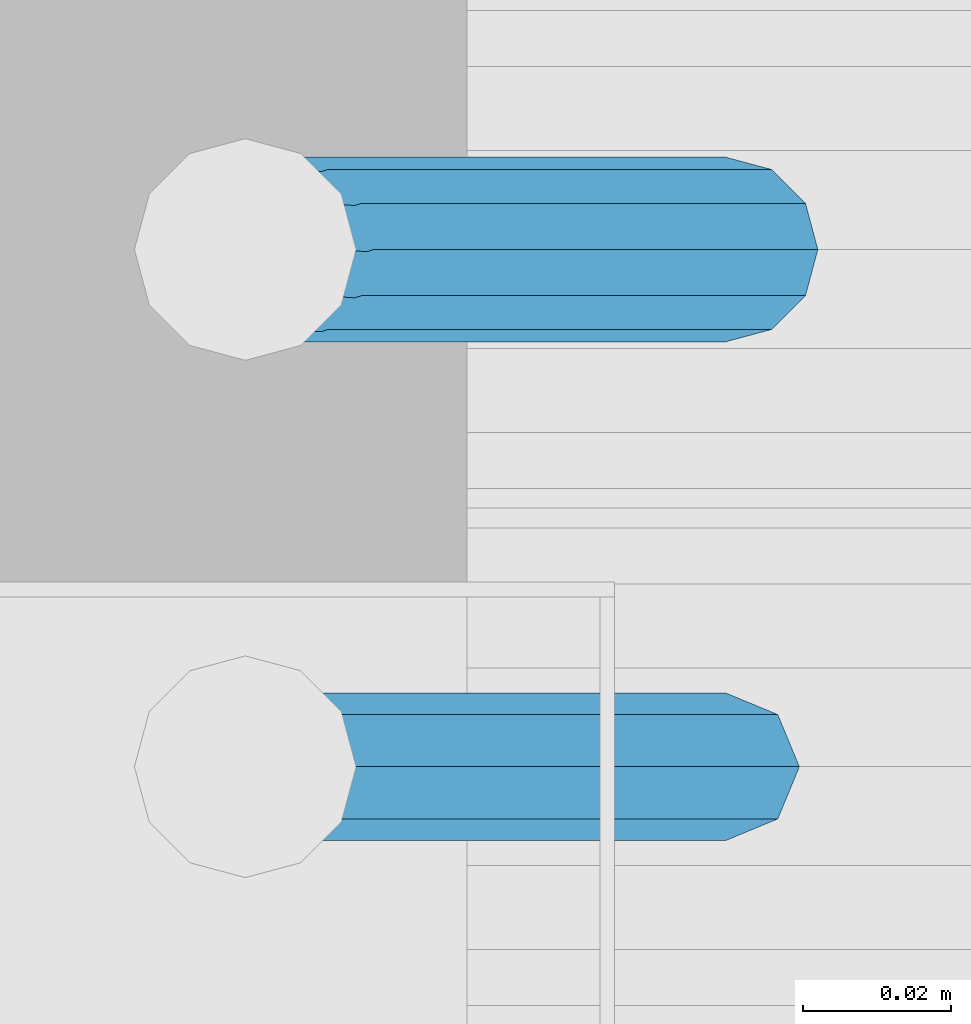
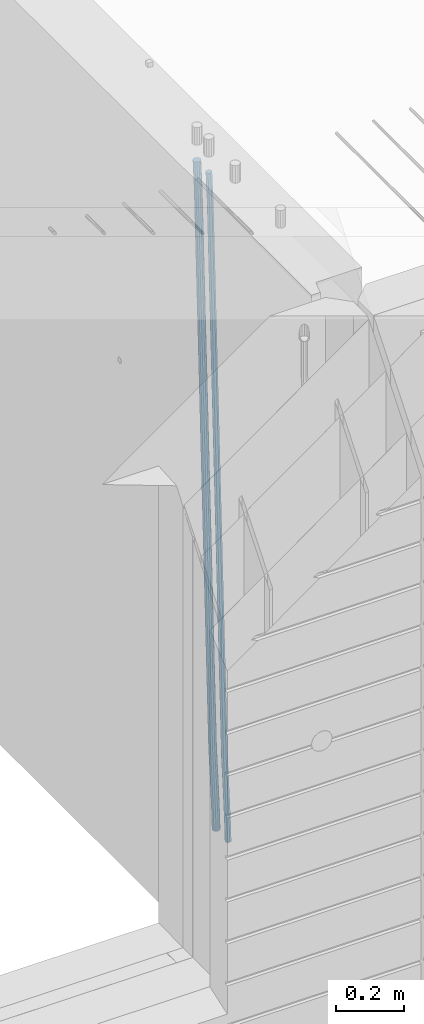
# One storey, part 102 of 350: 2 beams, 1 element without a shape of its own.
"""IFC2X3 building model written with IfcOpenShell, lengths in millimetres."""

from ifc_helpers import new_model, si_unit, frame, origin_with_axes, place, context, subcontext, project, spatial, faceted_brep, material, type_object, element, aggregate, save


model = new_model("IFC2X3")

# Units and contexts
model_context = context("Model", 3, precision=1e-05, world=origin_with_axes())
body_context = subcontext(model_context, "Body", "Model", "MODEL_VIEW")
ifc_project = project(units=[si_unit("LENGTHUNIT", "METRE", prefix="MILLI"), si_unit("AREAUNIT", "SQUARE_METRE"), si_unit("VOLUMEUNIT", "CUBIC_METRE"), si_unit("MASSUNIT", "GRAM", prefix="KILO"), si_unit("TIMEUNIT", "SECOND"), si_unit("PLANEANGLEUNIT", "RADIAN"), si_unit("SOLIDANGLEUNIT", "STERADIAN"), si_unit("THERMODYNAMICTEMPERATUREUNIT", "DEGREE_CELSIUS"), si_unit("LUMINOUSINTENSITYUNIT", "LUMEN")], contexts=[model_context])

# Site, building, storey
site_placement = place(None, origin_with_axes())
site = spatial("IfcSite", under=ifc_project, at=site_placement, CompositionType="ELEMENT")
building_placement = place(site_placement, origin_with_axes())
building = spatial("IfcBuilding", under=site, at=building_placement, CompositionType="ELEMENT")
storey_placement = place(building_placement, origin_with_axes())
storey = spatial("IfcBuildingStorey", under=building, at=storey_placement, Name="2", CompositionType="ELEMENT", Elevation=0.0)

# Assembly, beams
assembly_placement = place(storey_placement, origin_with_axes())
assembly = element("IfcElementAssembly", 1, at=assembly_placement, inside=storey, AssemblyPlace="NOTDEFINED", PredefinedType="REINFORCEMENT_UNIT")
ifc_material = material()
beam_type_1 = type_object("IfcBeamType", Name="D20", PredefinedType="NOTDEFINED")
beam_1_placement = place(assembly_placement, frame((21875.0000022791, 8805.00000000393, 84990.0), z_axis=(-0.999642804636942, -0.000205726999925762, -0.0267249099902983), x_axis=(-0.0267249099948371, 4.30000201934385e-08, 0.999642825806181)))
beam_1 = element("IfcBeam", 2, at=beam_1_placement, type_object=beam_type_1, material=ifc_material, Name="JM20", ObjectType="D20", context=body_context, shape_type="Brep", body=[
    faceted_brep([(0.0, -10.0, 0.0), (-4.19531716033816e-08, -7.07106781186667, -7.07106781187031), (60.4266690400545, -7.0710677960451, -7.07106780570757), (60.4266690441291, -9.99999998418934, 6.15546014159918e-09), (0.0, 0.0, -10.0), (60.426669036824, 1.58106558956206e-08, -9.99999999384454), (4.196772351861e-08, 7.07106781186303, -7.07106781186667), (60.4266690363438, 7.07106782768096, -7.07106780570757), (0.0, 10.0, 0.0), (60.4266690388904, 10.0000000158179, 6.15182216279209e-09), (4.196772351861e-08, 7.07106781185939, 7.07106781185939), (60.4266690429649, 7.07106782768096, 7.07106781802577), (0.0, 0.0, 10.0), (60.4266690461809, 1.58179318532348e-08, 10.0000000061555), (-4.19531716033816e-08, -7.07106781187031, 7.07106781185939), (60.4266690466611, -7.07106779605238, 7.07106781802213), (61.0378400410118, -7.07106779588503, -7.07106780564936), (60.991799419251, -9.99999998403655, 6.21366780251265e-09), (61.0569027789461, 1.5985278878361e-08, -9.99999999378269), (61.0378209396877, 7.07106782784831, -7.07106780564936), (60.9917724058905, 10.0000000159635, 6.21366780251265e-09), (60.9457317841297, 7.07106782781193, 7.0710678180767), (60.9266690461809, 1.59488990902901e-08, 10.0000000062028), (60.9457508854539, -7.07106779591413, 7.0710678180767), (61.6489592143771, -7.07106614513759, -7.06310863441468), (61.5568818710308, -9.9999984576425, 0.00735959856683621), (61.6870830769039, 1.71821739058942e-06, -9.99179257185824), (61.6489210170112, 7.07106947854481, -7.06310888312146), (61.556827851804, 10.0000015422847, 0.00735924683976918), (61.4647505084577, 7.07106922979438, 7.07782747982128), (61.4266266459163, 1.36643211590126e-06, 10.0065114172685), (61.464788705809, -7.07106639389531, 7.07782772852806), (176.543135720174, -7.07075579406956, -5.56673531796696), (176.451058376813, -9.99968810657447, 1.50373291501455), (176.581259582701, 0.000312069292704109, -8.49541925541052), (176.543097522794, 7.07137982961285, -5.56673556667374), (176.451004357587, 10.00031189336, 1.50373256329476), (176.35892701424, 7.07137958085514, 8.57420079627263), (176.320803151699, 0.000311717507429421, 11.5028847337162), (176.358965211621, -7.07075604281999, 8.57420104497578), (177.098753836006, -7.07075429323595, -5.55949898843028), (176.98362511232, -9.99968666800123, 1.510669025065), (177.146421932586, 0.000313595905026887, -8.48805862247536), (177.098706077581, 7.07138133041735, -5.55949936166144), (176.983557571715, 10.0003133318824, 1.51066849724157), (176.868428848029, 7.07138095712435, 8.58083651073321), (176.820760751449, 0.000313067976094317, 11.5093961447819), (176.868476606425, -7.07075466652896, 8.58083688396073), (177.654312950661, -7.07075204110879, -5.54863964998367), (177.516135294456, -9.99968450931192, 1.52107783331303), (177.711524267797, 0.000315886711177882, -8.47701274570863), (177.654255632195, 7.07138358250813, -5.54864021007961), (177.516054233929, 10.0003154905207, 1.5210770412159), (177.377876577739, 7.0713830223176, 8.59079452451624), (177.320665260588, 0.000315094497636892, 11.5191676202448), (177.377933896176, -7.07075260129932, 8.59079508461218), (299.499456785634, -7.07025810522464, -3.16697112782276), (299.361279129444, -9.99919057342777, 3.90274635547394), (299.556668102785, 0.000809822595329024, -6.09534422354773), (299.499399467197, 7.07187751838501, -3.1669716879187), (299.361198068917, 10.0008094264049, 3.90274556338045), (299.223020412712, 7.07187695819448, 10.9724630466735), (299.165809095575, 0.000809030381788034, 13.9008361423985), (299.223077731163, -7.07025866542244, 10.9724636067695), (300.03174732349, -7.07025594743027, -3.15656661289177), (299.971788958996, -9.99918809853989, 3.91467979818117), (300.056572611924, 0.000811849109595641, -6.08557274808481), (300.031722507032, 7.07187967631762, -3.15656653768019), (299.971753863239, 10.0008119014747, 3.91467990454839), (299.91179549876, 7.07187975035777, 10.9859263156177), (299.886970210311, 0.000811953817901667, 13.9149324508144), (299.911820315203, -7.0702558733974, 10.9859262404061), (300.564137759997, -7.07025623699155, -3.15794273276697), (300.582413367199, -9.99918843065097, 3.91310145956595), (300.556570941641, 0.000811577163403854, -6.0868651410201), (300.564145451674, 7.07187938674906, -3.15794274158179), (300.582424244858, 10.0008115693345, 3.91310144710224), (300.600699852032, 7.07187937566778, 10.9841456394352), (300.608266670402, 0.000811561512819026, 13.9130680476919), (300.600692160384, -7.07025624805829, 10.98414564825), (2294.16589219622, -7.0713405251372, -8.31099358700158), (2294.1841678034, -10.0002727187966, -1.23994939466866), (2294.15832537785, -0.000272710982244462, -11.2399159952547), (2294.16589988787, 7.07079509858886, -8.31099359582004), (2294.18417868105, 9.99972728118883, -1.23994940713601), (2294.20245428824, 7.07079508752213, 5.83109478519327), (2294.2100211066, -0.00027272663282929, 8.76001719345368), (2294.20244659658, -7.07134053620393, 5.83109479401173), (2294.7782683276, -7.07134085819416, -8.31257645345977), (2294.72126025338, -10.000273010919, -1.24133766827799), (2294.84007459224, -0.000273081772320438, -11.2416781768807), (2294.87047377572, 7.07079471537872, -8.31281477453012), (2294.85165844864, 9.9997269181622, -1.24167470516841), (2294.7946503744, 7.07079476544459, 5.82956408001337), (2294.73284410976, -0.000273010977252852, 8.75866580342336), (2294.7024449263, -7.07134080815013, 5.82980240107645), (2295.39054023061, -7.0793250091956, -8.30442771922026), (2295.25826128852, -10.0072756143927, -1.23419071494573), (2295.52170777075, -0.00916171800054144, -11.2326063125765), (2295.57492774284, 7.06160849139269, -8.30343918807193), (2295.51902460904, 9.99102432676591, -1.23279272078435), (2295.38674566693, 7.06307372157607, 5.83744428349019), (2295.25557812679, -0.0070895696117077, 8.76562287684646), (2295.20235815471, -7.07785977901949, 5.83645575234186), (2317.1947101649, -7.36365585014573, -8.01423575520312), (2317.06243122277, -10.2916064553428, -0.94399875092131), (2317.32587770502, -0.293492558957951, -10.9424143485521), (2317.37909767711, 6.77727765044983, -8.01324722405116), (2317.32319454331, 9.70669348581578, -0.942600756767206), (2317.1909156012, 6.77874288063322, 6.12763624751096), (2317.05974806109, -0.291420410569117, 9.0558148408636), (2317.00652808898, -7.36219061996962, 6.12664771636264), (2317.83015404257, -7.37194216843636, -8.00577862486898), (2317.72252095213, -10.300214160583, -0.935213608652703), (2317.90419832576, -0.301033978277701, -10.9347174723516), (2317.90127966482, 6.77046829039318, -8.00629749759901), (2317.82310777172, 9.70017451494641, -0.935947405505431), (2317.71547468127, 6.77190252279979, 6.13461761071085), (2317.64143039809, -0.29900566735887, 9.06355645819713), (2317.64434905903, -7.37050793602975, 6.13513648344451), (2318.46565174212, -7.3700661537805, -7.99751648408346), (2318.38266643914, -10.2982456018653, -0.926623872735945), (2318.48256818345, -0.299336209594912, -10.9272153854981), (2318.42350634121, 6.77200652527245, -7.99954269419686), (2318.32306384158, 9.70166538090416, -0.929489366557391), (2318.2400785386, 6.77348593281204, 6.14140324480104), (2318.22316209726, -0.297244011366274, 9.07110214621207), (2318.2822239395, -7.36858674623363, 6.1434294549108), (2418.48643733139, -7.07180401323421, -6.70013846199799), (2418.4034520284, -9.99998346132634, 0.370754149349523), (2418.5033537727, -0.00107406904135132, -9.62983736341266), (2418.44429193046, 7.07026866581873, -6.70216467211139), (2418.34384943081, 9.99992752145772, 0.367888655531715), (2418.26086412782, 7.0717480733656, 7.43878126688651), (2418.24394768651, 0.00101812917273492, 10.3684801682975), (2418.30300952874, -7.07032460568735, 7.44080747699627)], [[[0, 1, 2, 3]], [[1, 4, 5, 2]], [[4, 6, 7, 5]], [[6, 8, 9, 7]], [[8, 10, 11, 9]], [[10, 12, 13, 11]], [[12, 14, 15, 13]], [[14, 0, 3, 15]], [[14, 12, 10, 8, 6, 4, 1, 0]], [[3, 2, 16, 17]], [[2, 5, 18, 16]], [[5, 7, 19, 18]], [[7, 9, 20, 19]], [[9, 11, 21, 20]], [[11, 13, 22, 21]], [[13, 15, 23, 22]], [[15, 3, 17, 23]], [[17, 16, 24, 25]], [[16, 18, 26, 24]], [[18, 19, 27, 26]], [[19, 20, 28, 27]], [[20, 21, 29, 28]], [[21, 22, 30, 29]], [[22, 23, 31, 30]], [[23, 17, 25, 31]], [[25, 24, 32, 33]], [[24, 26, 34, 32]], [[26, 27, 35, 34]], [[27, 28, 36, 35]], [[28, 29, 37, 36]], [[29, 30, 38, 37]], [[30, 31, 39, 38]], [[31, 25, 33, 39]], [[33, 32, 40, 41]], [[32, 34, 42, 40]], [[34, 35, 43, 42]], [[35, 36, 44, 43]], [[36, 37, 45, 44]], [[37, 38, 46, 45]], [[38, 39, 47, 46]], [[39, 33, 41, 47]], [[41, 40, 48, 49]], [[40, 42, 50, 48]], [[42, 43, 51, 50]], [[43, 44, 52, 51]], [[44, 45, 53, 52]], [[45, 46, 54, 53]], [[46, 47, 55, 54]], [[47, 41, 49, 55]], [[49, 48, 56, 57]], [[48, 50, 58, 56]], [[50, 51, 59, 58]], [[51, 52, 60, 59]], [[52, 53, 61, 60]], [[53, 54, 62, 61]], [[54, 55, 63, 62]], [[55, 49, 57, 63]], [[57, 56, 64, 65]], [[56, 58, 66, 64]], [[58, 59, 67, 66]], [[59, 60, 68, 67]], [[60, 61, 69, 68]], [[61, 62, 70, 69]], [[62, 63, 71, 70]], [[63, 57, 65, 71]], [[65, 64, 72, 73]], [[64, 66, 74, 72]], [[66, 67, 75, 74]], [[67, 68, 76, 75]], [[68, 69, 77, 76]], [[69, 70, 78, 77]], [[70, 71, 79, 78]], [[71, 65, 73, 79]], [[73, 72, 80, 81]], [[72, 74, 82, 80]], [[74, 75, 83, 82]], [[75, 76, 84, 83]], [[76, 77, 85, 84]], [[77, 78, 86, 85]], [[78, 79, 87, 86]], [[79, 73, 81, 87]], [[81, 80, 88, 89]], [[80, 82, 90, 88]], [[82, 83, 91, 90]], [[83, 84, 92, 91]], [[84, 85, 93, 92]], [[85, 86, 94, 93]], [[86, 87, 95, 94]], [[87, 81, 89, 95]], [[89, 88, 96, 97]], [[88, 90, 98, 96]], [[90, 91, 99, 98]], [[91, 92, 100, 99]], [[92, 93, 101, 100]], [[93, 94, 102, 101]], [[94, 95, 103, 102]], [[95, 89, 97, 103]], [[97, 96, 104, 105]], [[96, 98, 106, 104]], [[98, 99, 107, 106]], [[99, 100, 108, 107]], [[100, 101, 109, 108]], [[101, 102, 110, 109]], [[102, 103, 111, 110]], [[103, 97, 105, 111]], [[105, 104, 112, 113]], [[104, 106, 114, 112]], [[106, 107, 115, 114]], [[107, 108, 116, 115]], [[108, 109, 117, 116]], [[109, 110, 118, 117]], [[110, 111, 119, 118]], [[111, 105, 113, 119]], [[113, 112, 120, 121]], [[112, 114, 122, 120]], [[114, 115, 123, 122]], [[115, 116, 124, 123]], [[116, 117, 125, 124]], [[117, 118, 126, 125]], [[118, 119, 127, 126]], [[119, 113, 121, 127]], [[121, 120, 128, 129]], [[120, 122, 130, 128]], [[122, 123, 131, 130]], [[123, 124, 132, 131]], [[124, 125, 133, 132]], [[125, 126, 134, 133]], [[126, 127, 135, 134]], [[127, 121, 129, 135]], [[130, 131, 132, 133, 134, 135, 129, 128]]]),
])
beam_type_2 = type_object("IfcBeamType", Name="D25", PredefinedType="NOTDEFINED")
beam_2_placement = place(assembly_placement, frame((21875.0000022791, 8875.00000000393, 84990.0), z_axis=(-0.999642804636942, -0.000205726999925762, -0.0267249099902983), x_axis=(-0.0267249099948371, 4.30000201934385e-08, 0.999642825806181)))
beam_2 = element("IfcBeam", 3, at=beam_2_placement, type_object=beam_type_2, material=ifc_material, Name="JM25", ObjectType="D25", context=body_context, shape_type="Brep", body=[
    faceted_brep([(-7.41420080885291e-08, -12.5, -3.63797880709171e-12), (-6.42030499875546e-08, -10.8253175473074, -6.25000000000364), (60.4103898235917, -10.8253175318459, -6.2499999938409), (60.4103898269532, -12.4999999845422, 6.16273609921336e-09), (-3.70782800018787e-08, -6.25000000000364, -10.8253175473074), (60.4103898202884, -6.24999998454587, -10.8253175411446), (-1.45519152283669e-11, -3.63797880709171e-12, -12.5), (60.4103898179019, 1.54577719513327e-08, -12.4999999938373), (3.70637280866504e-08, 6.25, -10.8253175473074), (60.410389817087, 6.25000001545777, -10.825317541141), (6.42030499875546e-08, 10.8253175473001, -6.25000000000364), (60.410389818062, 10.8253175627578, -6.24999999383726), (7.41420080885291e-08, 12.4999999999927, 0.0), (60.4103898205503, 12.5000000154541, 6.16273609921336e-09), (6.42176019027829e-08, 10.8253175473001, 6.24999999999636), (60.4103898238973, 10.8253175627651, 6.2500000061591), (3.70928319171071e-08, 6.24999999999636, 10.8253175473037), (60.4103898272151, 6.25000001546141, 10.8253175534664), (1.45519152283669e-11, -3.63797880709171e-12, 12.4999999999964), (60.4103898296162, 1.54541339725256e-08, 12.5000000061591), (-3.7049176171422e-08, -6.25000000000364, 10.8253175473001), (60.4103898304165, -6.24999998454587, 10.8253175534701), (-6.41884980723262e-08, -10.8253175473074, 6.25), (60.4103898294561, -10.8253175318459, 6.25000000616637), (61.0324985728803, -10.8253175316895, -6.24999999377542), (60.991802792938, -12.4999999843931, 6.22458173893392e-09), (61.0622854283865, -6.24999998437852, -10.8253175410755), (61.0731819955545, 1.5628756955266e-08, -12.4999999937718), (61.0622685480339, 6.25000001562512, -10.8253175410791), (61.032469335245, 10.8253175629216, -6.24999999377178), (60.9917690322181, 12.5000000156033, 6.22458173893392e-09), (60.9510732522613, 10.8253175629034, 6.25000000621731), (60.9212863967696, 6.25000001558874, 10.8253175535247), (60.9103898296162, 1.55814632307738e-08, 12.5000000062137), (60.9213032771368, -6.24999998441126, 10.8253175535174), (60.9511024898966, -10.8253175317113, 6.25000000621731), (61.6545545670233, -10.8253158516927, -6.24189838219536), (61.573166454793, -12.499998414296, 0.00757164385504439), (61.7141257553885, -6.24999822394238, -10.8168280205282), (61.7359179680789, 1.80548886419274e-06, -12.491368569139), (61.7140919992817, 6.25000177601396, -10.8168282403167), (61.6544960997562, 10.8253192428383, -6.2418987628771), (61.5730989426083, 12.5000015856094, 0.0075712042817031), (61.4917108303925, 10.8253190230062, 6.25704123032847), (61.4321396420273, 6.25000139525582, 10.8319708686649), (61.4103474293224, 1.36582457344048e-06, 12.5065114172721), (61.4321733981196, -6.24999860470052, 10.8319710884571), (61.4917692976451, -10.8253160715249, 6.25704161101385), (176.524302641745, -10.8250056210964, -4.74584321979273), (176.442914529529, -12.4996881836996, 1.50362680625403), (176.583873830095, -6.24968799334965, -9.3207728581292), (176.605666042786, 0.000312036081595579, -10.9953134067364), (176.583840074018, 6.25031200660669, -9.32077307791769), (176.524244174492, 10.8256294734347, -4.74584360047811), (176.44284701733, 12.5003118162058, 1.50362636668069), (176.361458905099, 10.8256292535989, 7.75309639272746), (176.301887716749, 6.25031162585219, 12.3280260310676), (176.280095504058, 0.000311596420942806, 14.0025665796711), (176.301921472827, -6.24968837410415, 12.3280262508561), (176.361517372367, -10.8250058409321, 7.75309677341284), (177.085397012124, -10.8250041057399, -4.73853556792164), (176.983633547483, -12.4996867233749, 1.51066909103247), (177.159881729676, -6.24968643771717, -9.31327097355097), (177.187129580227, 0.000313606451527448, -10.987740468332), (177.159839524218, 6.25031356221734, -9.31327130338468), (177.085323910098, 10.8256309887511, -4.73853613920801), (176.983549136537, 12.5003132764905, 1.51066843136869), (176.881785671867, 10.8256306588555, 7.7598730903228), (176.80730095433, 6.25031299082912, 12.3346084959521), (176.780053103794, 0.000312946667690994, 14.0090779907332), (176.807343159802, -6.2496870091054, 12.3346088257895), (176.881858773908, -10.8250044356355, 7.7598736616128), (177.646431799818, -10.8250018318176, -4.72756919822132), (177.524295146417, -12.4996845320202, 1.52123723245313), (177.735828462886, -6.24968410334986, -9.30201312475765), (177.768531371941, 0.00031596292683389, -10.9763759912421), (177.735777808921, 6.25031589654827, -9.30201361973741), (177.646344064575, 10.8256332626152, -4.72757005553649), (177.524193838486, 12.5003154677688, 1.52123624250817), (177.402057185071, 10.8256327675663, 7.77004267317898), (177.312660521988, 6.2503150390985, 12.3444865997226), (177.279957612933, 0.00031497282179771, 14.0188494661961), (177.312711175953, -6.24968496079964, 12.3444870946951), (177.402144920314, -10.8250023268702, 7.77004353049415), (299.455768830812, -10.8245081283076, -2.3466005802984), (299.333632177397, -12.4991908285119, 3.90220585037241), (299.545165493895, -6.24919039983797, -6.92104450684201), (299.577868402965, 0.000809666431450751, -8.59540737331918), (299.545114839959, 6.25080960005653, -6.92104500181449), (299.455681095627, 10.826126966127, -2.34660143761721), (299.333530869539, 12.5008091712825, 3.90220486042381), (299.211394216109, 10.8261264710764, 10.1510112911019), (299.12199755304, 6.25080874260857, 14.7254552176419), (299.089294643942, 0.000808676333690528, 16.399818084119), (299.122048206962, -6.24919125728957, 14.725455712618), (299.211481951279, -10.8245086233583, 10.1510121484171), (300.024791154356, -10.8245058220109, -2.33547808076037), (299.97179243555, -12.4991882411778, 3.91467976726199), (300.063582369272, -6.24918829865055, -6.91091117600809), (300.077772912133, 0.000811692589195445, -8.58563589785263), (300.063560438372, 6.250811701364, -6.91091110953494), (300.02475316888, 10.8261292726274, -2.33547796563289), (299.971750386685, 12.5008117588586, 3.91467993563856), (299.918751667865, 10.8261293380583, 10.1648377836791), (299.879960452934, 6.25081181469795, 14.7402708789268), (299.865769910102, 0.000811823456388083, 16.4149956007714), (299.879982383849, -6.2491881853166, 14.7402708124573), (299.918789653355, -10.8245057565764, 10.1648376685516), (300.593920270287, -10.8245061315029, -2.33694916256718), (300.610074274839, -12.4991885890868, 3.91302995994556), (300.582096539598, -6.24918858061756, -6.91225142858093), (300.577771241835, 0.000811420690297382, -8.58692829078791), (300.582103337059, 6.25081141938063, -6.91225143636984), (300.593932043848, 10.8261289631064, -2.33694917606044), (300.610087869776, 12.5008114109114, 3.9130299443641), (300.626241874328, 10.8261289533239, 10.1630090668841), (300.638065605017, 6.25081140244038, 14.7383113328942), (300.642390902765, 0.000811401132523315, 16.4129881951012), (300.638058807541, -6.24918859755599, 14.7383113406868), (300.626230100752, -10.8245061412817, 10.1630090803737), (2294.14353285028, -10.8255902228266, -7.48986524046995), (2294.15968685482, -12.5002726804123, -1.23988611794994), (2294.13170911958, -6.25027267194127, -12.0651675064764), (2294.12738382183, -0.000272670631602523, -13.7398443686834), (2294.13171591706, 6.24972732805691, -12.0651675142726), (2294.14354462385, 10.8250448717827, -7.48986525395958), (2294.15970044976, 12.4997273195859, -1.23988613352776), (2294.17585445431, 10.8250448620001, 5.01009298898498), (2294.187678185, 6.24972731111666, 9.58539525499873), (2294.19200348278, -0.000272690191195579, 11.2600721172021), (2294.18767138754, -6.2502726888797, 9.585395262784), (2294.17584268075, -10.8255902326073, 5.0100930024746), (2294.74938878331, -10.8255905522892, -7.49143125355113), (2294.70496048078, -12.5002729769312, -1.24129553822058), (2294.80375011452, -6.25027303739807, -12.0669045943469), (2294.85347839963, -0.00027306548145134, -13.7417211739557), (2294.88524898475, 6.24972691828589, -12.0671152424002), (2294.89054896731, 10.8250444655641, -7.49179610668216), (2294.86795822125, 12.4997269344367, -1.2417168343236), (2294.82352991869, 10.8250445097965, 5.00841888100695), (2294.76916858749, 6.24972699490354, 9.58389222179903), (2294.71944030239, -0.000272977013082709, 11.2587088014079), (2294.68766971726, -6.2502729607786, 9.58410286985236), (2294.68236973471, -10.825590508055, 5.0087837341307), (2295.35514159774, -10.8334896929118, -7.48336928222852), (2295.25014129943, -12.5073822463346, -1.23403972030064), (2295.47567672595, -6.25903509786804, -12.0579619151831), (2295.5794493938, -0.00973987576071522, -13.7320592174692), (2295.63865379873, 6.23990236538521, -12.0570881688836), (2295.63742616826, 10.8153050340698, -7.48185590923822), (2295.57609544498, 12.4904926801701, -1.23229222769442), (2295.47109514667, 10.8166001267491, 5.01703733422983), (2295.35056001844, 6.24214553170532, 9.59162996718442), (2295.24678735061, -0.00714969040200231, 11.2657272694705), (2295.18758294567, -6.2567919315461, 9.59075622088494), (2295.18881057615, -10.8321946002325, 5.01552396123952), (2317.11481405119, -11.1172402731609, -7.19376954593827), (2317.00981375287, -12.7911328265836, -0.944439984010387), (2317.23534917941, -6.54278567811707, -11.7683621788929), (2317.33912184725, -0.29349045600793, -13.4424594811753), (2317.39832625218, 5.95615178513435, -11.7674884325897), (2317.3970986217, 10.5315544538207, -7.19225617294796), (2317.33576789842, 12.2067420999228, -0.942692491407797), (2317.23076760011, 10.5328495465001, 5.30663707051644), (2317.1102324719, 5.95839495145628, 9.88122970347831), (2317.00645980405, -0.290900270651036, 11.5553270057644), (2316.94725539912, -6.54054251179696, 9.8803559571752), (2316.94848302958, -11.1159451804797, 5.30512369752978), (2317.8004851227, -11.126181564201, -7.18464394159309), (2317.70994759697, -12.80026271514, -0.935121894457552), (2317.8836082904, -6.55123910954353, -11.7597344907699), (2317.93704431444, -0.301287487300215, -13.4345017240375), (2317.94647505535, 5.94900381260777, -11.7601931137251), (2317.90937355367, 10.5248742839121, -7.18543829986083), (2317.83568112683, 12.2002231291572, -0.936039140375215), (2317.74514360113, 10.52614197822, 5.31348290676033), (2317.6620204334, 5.95119952355708, 9.88857345594079), (2317.60858440938, -0.298752098682598, 11.5633406892048), (2317.59915366847, -6.54904339859058, 9.88903207889598), (2317.63625517016, -11.124913869895, 5.31427726503171), (2318.48621414759, -11.1241535473946, -7.1757201348446), (2318.41014051515, -12.7981747344165, -0.926005966604862), (2318.53192237136, -6.54933498770879, -11.7513083179474), (2318.53501770479, -0.299537993947524, -13.426745357352), (2318.4946707558, 5.95060937655398, -11.7530992513966), (2318.42169245677, 10.5263851832951, -7.17882212257246), (2318.33563728402, 12.2017139941127, -0.929587833499681), (2318.25956365156, 10.5276928070889, 5.32012633473278), (2318.21385542781, 5.95287424740127, 9.89571451784286), (2318.21076009437, -0.296922746361815, 11.5711515572511), (2318.25110704337, -6.54707011686151, 9.89750545128845), (2318.32408534238, -11.1228459236008, 5.32322832246064), (2418.48697597762, -10.8259511810775, -5.87860183186422), (2418.41090234517, -12.4999723680994, 0.371112336375518), (2418.53268420139, -6.25113262138984, -10.454190014967), (2418.53577953482, -0.00133562762675865, -12.1296270543789), (2418.49543258583, 6.24881174287475, -10.4559809484163), (2418.4224542868, 10.8245875496141, -5.88170381958844), (2418.33639911404, 12.499916360428, 0.367530469480698), (2418.26032548158, 10.8258951734078, 6.61724463772043), (2418.21461725782, 6.25107661372022, 11.1928328208196), (2418.21152192439, 0.00127961995895021, 12.8682698602315), (2418.25186887338, -6.24886775054256, 11.1946237542688), (2418.32484717241, -10.8246435572837, 6.62034662544102)], [[[0, 1, 2, 3]], [[1, 4, 5, 2]], [[4, 6, 7, 5]], [[6, 8, 9, 7]], [[8, 10, 11, 9]], [[10, 12, 13, 11]], [[12, 14, 15, 13]], [[14, 16, 17, 15]], [[16, 18, 19, 17]], [[18, 20, 21, 19]], [[20, 22, 23, 21]], [[22, 0, 3, 23]], [[22, 20, 18, 16, 14, 12, 10, 8, 6, 4, 1, 0]], [[3, 2, 24, 25]], [[2, 5, 26, 24]], [[5, 7, 27, 26]], [[7, 9, 28, 27]], [[9, 11, 29, 28]], [[11, 13, 30, 29]], [[13, 15, 31, 30]], [[15, 17, 32, 31]], [[17, 19, 33, 32]], [[19, 21, 34, 33]], [[21, 23, 35, 34]], [[23, 3, 25, 35]], [[25, 24, 36, 37]], [[24, 26, 38, 36]], [[26, 27, 39, 38]], [[27, 28, 40, 39]], [[28, 29, 41, 40]], [[29, 30, 42, 41]], [[30, 31, 43, 42]], [[31, 32, 44, 43]], [[32, 33, 45, 44]], [[33, 34, 46, 45]], [[34, 35, 47, 46]], [[35, 25, 37, 47]], [[37, 36, 48, 49]], [[36, 38, 50, 48]], [[38, 39, 51, 50]], [[39, 40, 52, 51]], [[40, 41, 53, 52]], [[41, 42, 54, 53]], [[42, 43, 55, 54]], [[43, 44, 56, 55]], [[44, 45, 57, 56]], [[45, 46, 58, 57]], [[46, 47, 59, 58]], [[47, 37, 49, 59]], [[49, 48, 60, 61]], [[48, 50, 62, 60]], [[50, 51, 63, 62]], [[51, 52, 64, 63]], [[52, 53, 65, 64]], [[53, 54, 66, 65]], [[54, 55, 67, 66]], [[55, 56, 68, 67]], [[56, 57, 69, 68]], [[57, 58, 70, 69]], [[58, 59, 71, 70]], [[59, 49, 61, 71]], [[61, 60, 72, 73]], [[60, 62, 74, 72]], [[62, 63, 75, 74]], [[63, 64, 76, 75]], [[64, 65, 77, 76]], [[65, 66, 78, 77]], [[66, 67, 79, 78]], [[67, 68, 80, 79]], [[68, 69, 81, 80]], [[69, 70, 82, 81]], [[70, 71, 83, 82]], [[71, 61, 73, 83]], [[73, 72, 84, 85]], [[72, 74, 86, 84]], [[74, 75, 87, 86]], [[75, 76, 88, 87]], [[76, 77, 89, 88]], [[77, 78, 90, 89]], [[78, 79, 91, 90]], [[79, 80, 92, 91]], [[80, 81, 93, 92]], [[81, 82, 94, 93]], [[82, 83, 95, 94]], [[83, 73, 85, 95]], [[85, 84, 96, 97]], [[84, 86, 98, 96]], [[86, 87, 99, 98]], [[87, 88, 100, 99]], [[88, 89, 101, 100]], [[89, 90, 102, 101]], [[90, 91, 103, 102]], [[91, 92, 104, 103]], [[92, 93, 105, 104]], [[93, 94, 106, 105]], [[94, 95, 107, 106]], [[95, 85, 97, 107]], [[97, 96, 108, 109]], [[96, 98, 110, 108]], [[98, 99, 111, 110]], [[99, 100, 112, 111]], [[100, 101, 113, 112]], [[101, 102, 114, 113]], [[102, 103, 115, 114]], [[103, 104, 116, 115]], [[104, 105, 117, 116]], [[105, 106, 118, 117]], [[106, 107, 119, 118]], [[107, 97, 109, 119]], [[109, 108, 120, 121]], [[108, 110, 122, 120]], [[110, 111, 123, 122]], [[111, 112, 124, 123]], [[112, 113, 125, 124]], [[113, 114, 126, 125]], [[114, 115, 127, 126]], [[115, 116, 128, 127]], [[116, 117, 129, 128]], [[117, 118, 130, 129]], [[118, 119, 131, 130]], [[119, 109, 121, 131]], [[121, 120, 132, 133]], [[120, 122, 134, 132]], [[122, 123, 135, 134]], [[123, 124, 136, 135]], [[124, 125, 137, 136]], [[125, 126, 138, 137]], [[126, 127, 139, 138]], [[127, 128, 140, 139]], [[128, 129, 141, 140]], [[129, 130, 142, 141]], [[130, 131, 143, 142]], [[131, 121, 133, 143]], [[133, 132, 144, 145]], [[132, 134, 146, 144]], [[134, 135, 147, 146]], [[135, 136, 148, 147]], [[136, 137, 149, 148]], [[137, 138, 150, 149]], [[138, 139, 151, 150]], [[139, 140, 152, 151]], [[140, 141, 153, 152]], [[141, 142, 154, 153]], [[142, 143, 155, 154]], [[143, 133, 145, 155]], [[145, 144, 156, 157]], [[144, 146, 158, 156]], [[146, 147, 159, 158]], [[147, 148, 160, 159]], [[148, 149, 161, 160]], [[149, 150, 162, 161]], [[150, 151, 163, 162]], [[151, 152, 164, 163]], [[152, 153, 165, 164]], [[153, 154, 166, 165]], [[154, 155, 167, 166]], [[155, 145, 157, 167]], [[157, 156, 168, 169]], [[156, 158, 170, 168]], [[158, 159, 171, 170]], [[159, 160, 172, 171]], [[160, 161, 173, 172]], [[161, 162, 174, 173]], [[162, 163, 175, 174]], [[163, 164, 176, 175]], [[164, 165, 177, 176]], [[165, 166, 178, 177]], [[166, 167, 179, 178]], [[167, 157, 169, 179]], [[169, 168, 180, 181]], [[168, 170, 182, 180]], [[170, 171, 183, 182]], [[171, 172, 184, 183]], [[172, 173, 185, 184]], [[173, 174, 186, 185]], [[174, 175, 187, 186]], [[175, 176, 188, 187]], [[176, 177, 189, 188]], [[177, 178, 190, 189]], [[178, 179, 191, 190]], [[179, 169, 181, 191]], [[181, 180, 192, 193]], [[180, 182, 194, 192]], [[182, 183, 195, 194]], [[183, 184, 196, 195]], [[184, 185, 197, 196]], [[185, 186, 198, 197]], [[186, 187, 199, 198]], [[187, 188, 200, 199]], [[188, 189, 201, 200]], [[189, 190, 202, 201]], [[190, 191, 203, 202]], [[191, 181, 193, 203]], [[194, 195, 196, 197, 198, 199, 200, 201, 202, 203, 193, 192]]]),
])
aggregate(assembly, [beam_1, beam_2])

save(model, "model.ifc")
